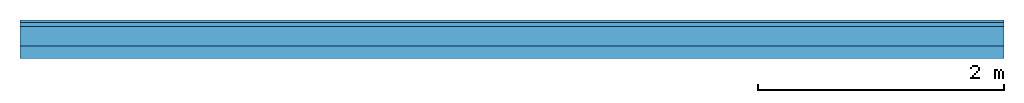
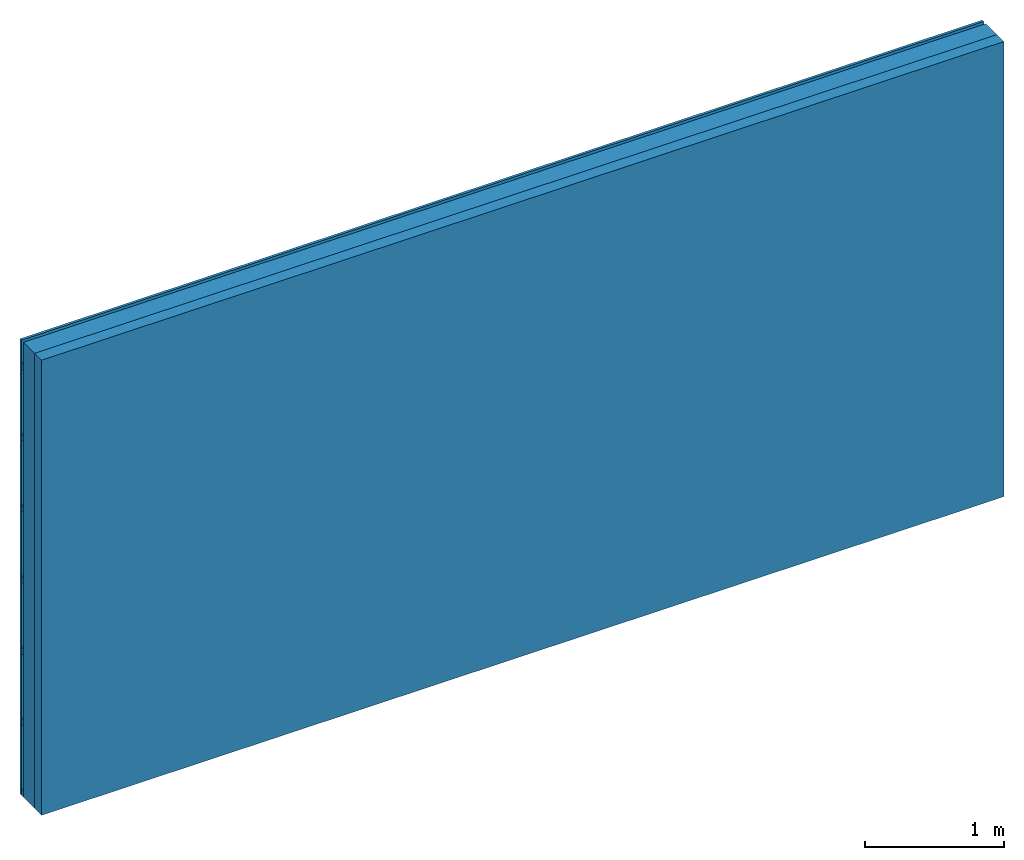
# One storey: 2 members, 2 plates, 1 element without a shape of its own.
"""IFC4 building model written with IfcOpenShell, lengths in metres."""

from ifc_helpers import new_model, si_unit, derived_unit, direction, frame, frame_2d, origin, origin_with_axes, place, context, project, spatial, rectangle, extrude, material, layer, layer_set, type_object, element, aggregate, save


model = new_model("IFC4")

# Units and contexts
plan_context = context("Plan", 3, precision=1e-05, world=origin(), true_north=direction((0.0, 1.0)))
model_context = context("Model", 3, precision=1e-05, world=origin(), true_north=direction((0.0, 1.0)))
ifc_project = project(units=[si_unit("LENGTHUNIT", "METRE"), derived_unit("SOUNDPRESSUREUNIT", [(si_unit("PRESSUREUNIT", "PASCAL", prefix="MICRO"), 0)]), si_unit("ENERGYUNIT", "JOULE", prefix="MEGA"), si_unit("MASSUNIT", "GRAM", prefix="KILO"), derived_unit("THERMALTRANSMITTANCEUNIT", [(si_unit("POWERUNIT", "WATT"), 1), (si_unit("AREAUNIT", "SQUARE_METRE"), -1), (si_unit("THERMODYNAMICTEMPERATUREUNIT", "KELVIN"), -1)]), derived_unit("AREADENSITYUNIT", [(si_unit("MASSUNIT", "GRAM", prefix="KILO"), 1), (si_unit("AREAUNIT", "SQUARE_METRE"), -1)]), derived_unit("USERDEFINED", [(si_unit("ENERGYUNIT", "JOULE", prefix="MEGA"), 1), (si_unit("AREAUNIT", "SQUARE_METRE"), -1)])], contexts=[plan_context, model_context])

# Site, building, storey
site = spatial("IfcSite", under=ifc_project)
building_placement = place(None, origin())
building = spatial("IfcBuilding", under=site, at=building_placement)
storey_placement = place(building_placement, origin())
storey = spatial("IfcBuildingStorey", under=building, at=storey_placement)

# Wall, members, plates
ifc_material_1 = material(Name="Wood cladding horizontal, closed")
ifc_layer_1 = layer(ifc_material_1, 0.022, Name="Cover 1st layer")
ifc_layer_2 = layer(None, 0.03, Name="Battens / profiles (ventilation)")
ifc_material_2 = material(Category="10.009")
ifc_layer_3 = layer(ifc_material_2, 0.16, Name="outside 2nd layer")
ifc_material_3 = material(Name="of the art")
ifc_layer_4 = layer(ifc_material_3, 0.0, Name="Bond")
ifc_layer_5 = layer(None, 0.1, Name="Support")
ifc_layer_set = layer_set([ifc_layer_1, ifc_layer_2, ifc_layer_3, ifc_layer_4, ifc_layer_5])
wall_type = type_object("IfcWallType", Name="D0917", PredefinedType="NOTDEFINED", material=ifc_layer_set)
wall_placement = place(None, frame((0.0, 0.0, 0.0), z_axis=(0.0, -1.0, 0.0), x_axis=(1.0, 0.0, 0.0)))
wall = element("IfcWall", 1, at=wall_placement, inside=storey, type_object=wall_type, material=ifc_layer_set, Name="Wall #1")
ifc_material_4 = material()
member_1_placement = place(wall_placement, origin())
member_1 = element("IfcMember", 2, at=member_1_placement, material=ifc_material_4, Name="Battens / profiles (ventilation)", context=plan_context, shape_type="SweptSolid", body=[
    extrude(rectangle(XDim=0.05, YDim=0.03, at=frame_2d((0.025, 0.015), x_axis=(1.0, 0.0))), frame((0.0, 0.0, 0.022), z_axis=(1.0, 0.0, 0.0), x_axis=(0.0, 1.0, 0.0)), (0.0, 0.0, 1.0), 8.0),
    extrude(rectangle(XDim=0.05, YDim=0.03, at=frame_2d((0.025, 0.015), x_axis=(1.0, 0.0))), frame((0.0, 0.625, 0.022), z_axis=(1.0, 0.0, 0.0), x_axis=(0.0, 1.0, 0.0)), (0.0, 0.0, 1.0), 8.0),
    extrude(rectangle(XDim=0.05, YDim=0.03, at=frame_2d((0.025, 0.015), x_axis=(1.0, 0.0))), frame((0.0, 1.25, 0.022), z_axis=(1.0, 0.0, 0.0), x_axis=(0.0, 1.0, 0.0)), (0.0, 0.0, 1.0), 8.0),
    extrude(rectangle(XDim=0.05, YDim=0.03, at=frame_2d((0.025, 0.015), x_axis=(1.0, 0.0))), frame((0.0, 1.875, 0.022), z_axis=(1.0, 0.0, 0.0), x_axis=(0.0, 1.0, 0.0)), (0.0, 0.0, 1.0), 8.0),
    extrude(rectangle(XDim=0.05, YDim=0.03, at=frame_2d((0.025, 0.015), x_axis=(1.0, 0.0))), frame((0.0, 2.5, 0.022), z_axis=(1.0, 0.0, 0.0), x_axis=(0.0, 1.0, 0.0)), (0.0, 0.0, 1.0), 8.0),
    extrude(rectangle(XDim=0.05, YDim=0.03, at=frame_2d((0.025, 0.015), x_axis=(1.0, 0.0))), frame((0.0, 3.125, 0.022), z_axis=(1.0, 0.0, 0.0), x_axis=(0.0, 1.0, 0.0)), (0.0, 0.0, 1.0), 8.0),
    extrude(rectangle(XDim=0.05, YDim=0.03, at=frame_2d((0.025, 0.015), x_axis=(1.0, 0.0))), frame((0.0, 3.75, 0.022), z_axis=(1.0, 0.0, 0.0), x_axis=(0.0, 1.0, 0.0)), (0.0, 0.0, 1.0), 8.0),
])
ifc_material_5 = material()
member_2_placement = place(wall_placement, origin())
member_2 = element("IfcMember", 3, at=member_2_placement, material=ifc_material_5, Name="Support", context=plan_context, shape_type="SweptSolid", body=[
    extrude(rectangle(XDim=1.0, YDim=0.1, at=frame_2d((0.5, 0.05), x_axis=(1.0, 0.0))), frame((0.0, 4.0, 0.212), z_axis=(0.0, -1.0, 0.0), x_axis=(1.0, 0.0, 0.0)), (0.0, 0.0, 1.0), 4.0),
    extrude(rectangle(XDim=1.0, YDim=0.1, at=frame_2d((0.5, 0.05), x_axis=(1.0, 0.0))), frame((1.0, 4.0, 0.212), z_axis=(0.0, -1.0, 0.0), x_axis=(1.0, 0.0, 0.0)), (0.0, 0.0, 1.0), 4.0),
    extrude(rectangle(XDim=1.0, YDim=0.1, at=frame_2d((0.5, 0.05), x_axis=(1.0, 0.0))), frame((2.0, 4.0, 0.212), z_axis=(0.0, -1.0, 0.0), x_axis=(1.0, 0.0, 0.0)), (0.0, 0.0, 1.0), 4.0),
    extrude(rectangle(XDim=1.0, YDim=0.1, at=frame_2d((0.5, 0.05), x_axis=(1.0, 0.0))), frame((3.0, 4.0, 0.212), z_axis=(0.0, -1.0, 0.0), x_axis=(1.0, 0.0, 0.0)), (0.0, 0.0, 1.0), 4.0),
    extrude(rectangle(XDim=1.0, YDim=0.1, at=frame_2d((0.5, 0.05), x_axis=(1.0, 0.0))), frame((4.0, 4.0, 0.212), z_axis=(0.0, -1.0, 0.0), x_axis=(1.0, 0.0, 0.0)), (0.0, 0.0, 1.0), 4.0),
    extrude(rectangle(XDim=1.0, YDim=0.1, at=frame_2d((0.5, 0.05), x_axis=(1.0, 0.0))), frame((5.0, 4.0, 0.212), z_axis=(0.0, -1.0, 0.0), x_axis=(1.0, 0.0, 0.0)), (0.0, 0.0, 1.0), 4.0),
    extrude(rectangle(XDim=1.0, YDim=0.1, at=frame_2d((0.5, 0.05), x_axis=(1.0, 0.0))), frame((6.0, 4.0, 0.212), z_axis=(0.0, -1.0, 0.0), x_axis=(1.0, 0.0, 0.0)), (0.0, 0.0, 1.0), 4.0),
    extrude(rectangle(XDim=1.0, YDim=0.1, at=frame_2d((0.5, 0.05), x_axis=(1.0, 0.0))), frame((7.0, 4.0, 0.212), z_axis=(0.0, -1.0, 0.0), x_axis=(1.0, 0.0, 0.0)), (0.0, 0.0, 1.0), 4.0),
])
plate_1_placement = place(wall_placement, origin())
plate_1 = element("IfcPlate", 4, at=plate_1_placement, material=ifc_material_1, Name="Cover 1st layer", context=plan_context, shape_type="SweptSolid", body=[
    extrude(rectangle(XDim=8.0, YDim=4.0, at=frame_2d((4.0, 2.0), x_axis=(1.0, 0.0))), origin_with_axes(), (0.0, 0.0, 1.0), 0.022),
])
plate_2_placement = place(wall_placement, origin())
plate_2 = element("IfcPlate", 5, at=plate_2_placement, material=ifc_material_2, Name="outside 2nd layer", context=plan_context, shape_type="SweptSolid", body=[
    extrude(rectangle(XDim=8.0, YDim=4.0, at=frame_2d((4.0, 2.0), x_axis=(1.0, 0.0))), frame((0.0, 0.0, 0.052), z_axis=(0.0, 0.0, 1.0), x_axis=(1.0, 0.0, 0.0)), (0.0, 0.0, 1.0), 0.16),
])
aggregate(wall, [plate_1, member_1, plate_2, member_2])

save(model, "model.ifc")
